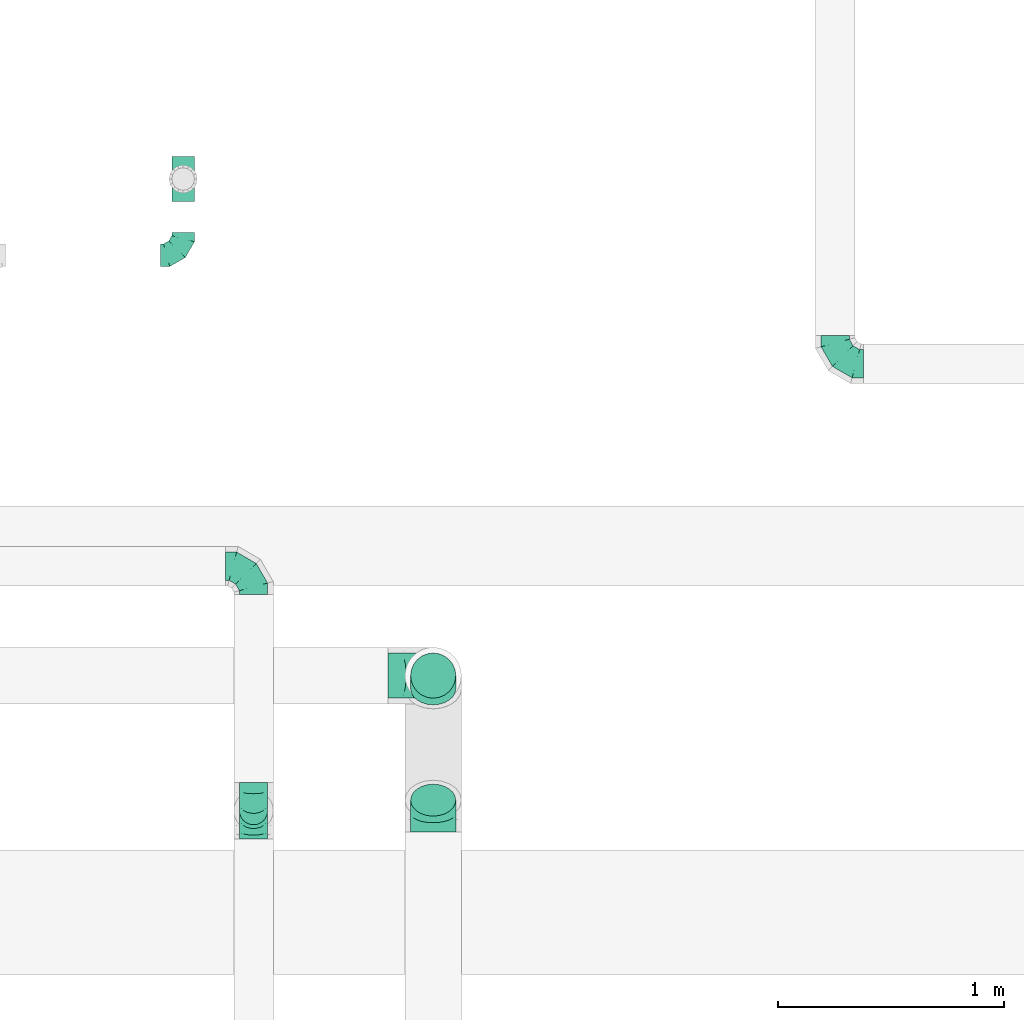
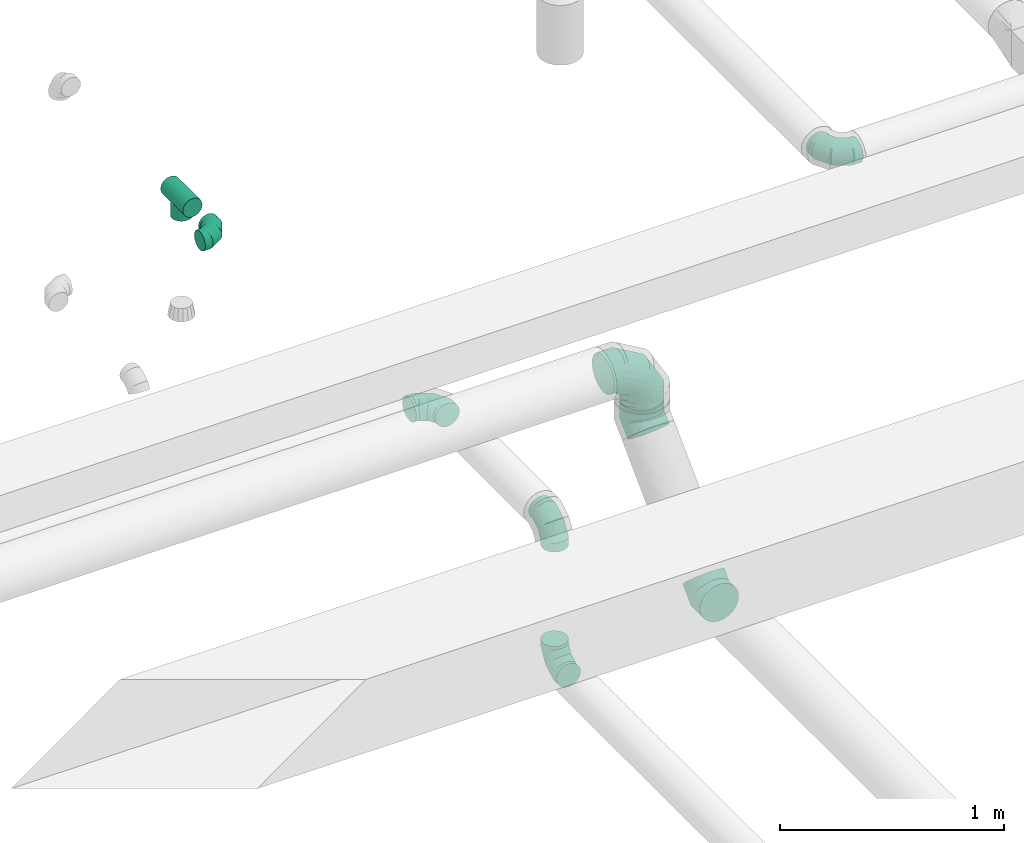
# One storey, part 71 of 97: 9 flow fittings.
"""IFC2X3 building model written with IfcOpenShell, lengths in millimetres."""

from ifc_helpers import new_model, entity, si_unit, converted_unit, derived_unit, direction, frame, origin, place, context, subcontext, project, spatial, faceted_brep, source, transform, mapped, material, type_object, type_shapes, element, save


model = new_model("IFC2X3")

# Units and contexts
model_context = context("Model", 3, precision=0.01, world=origin(), true_north=direction((6.12303176911189e-17, 1.0)))
body_context = subcontext(model_context, "Body", "Model", "MODEL_VIEW")
ifc_project = project(units=[si_unit("LENGTHUNIT", "METRE", prefix="MILLI"), si_unit("AREAUNIT", "SQUARE_METRE"), si_unit("VOLUMEUNIT", "CUBIC_METRE"), converted_unit("PLANEANGLEUNIT", "DEGREE", entity("IfcRatioMeasure", 0.0174532925199433), si_unit("PLANEANGLEUNIT", "RADIAN"), dimensions=[0, 0, 0, 0, 0, 0, 0]), si_unit("MASSUNIT", "GRAM", prefix="KILO"), derived_unit("MASSDENSITYUNIT", [(si_unit("MASSUNIT", "GRAM", prefix="KILO"), 1), (si_unit("LENGTHUNIT", "METRE"), -3)]), derived_unit("MOMENTOFINERTIAUNIT", [(si_unit("LENGTHUNIT", "METRE"), 4)]), si_unit("TIMEUNIT", "SECOND"), si_unit("FREQUENCYUNIT", "HERTZ"), si_unit("THERMODYNAMICTEMPERATUREUNIT", "DEGREE_CELSIUS"), derived_unit("THERMALTRANSMITTANCEUNIT", [(si_unit("MASSUNIT", "GRAM", prefix="KILO"), 1), (si_unit("THERMODYNAMICTEMPERATUREUNIT", "KELVIN"), -1), (si_unit("TIMEUNIT", "SECOND"), -3)]), derived_unit("VOLUMETRICFLOWRATEUNIT", [(si_unit("LENGTHUNIT", "METRE"), 3), (si_unit("TIMEUNIT", "SECOND"), -1)]), derived_unit("MASSFLOWRATEUNIT", [(si_unit("MASSUNIT", "GRAM", prefix="KILO"), 1), (si_unit("TIMEUNIT", "SECOND"), -1)]), derived_unit("ROTATIONALFREQUENCYUNIT", [(si_unit("TIMEUNIT", "SECOND"), -1)]), si_unit("ELECTRICCURRENTUNIT", "AMPERE"), si_unit("ELECTRICVOLTAGEUNIT", "VOLT"), si_unit("POWERUNIT", "WATT"), si_unit("FORCEUNIT", "NEWTON", prefix="KILO"), si_unit("ILLUMINANCEUNIT", "LUX"), si_unit("LUMINOUSFLUXUNIT", "LUMEN"), si_unit("LUMINOUSINTENSITYUNIT", "CANDELA"), derived_unit("USERDEFINED", [(si_unit("MASSUNIT", "GRAM", prefix="KILO"), -1), (si_unit("LENGTHUNIT", "METRE"), -2), (si_unit("TIMEUNIT", "SECOND"), 3), (si_unit("LUMINOUSFLUXUNIT", "LUMEN"), 1)]), derived_unit("LINEARVELOCITYUNIT", [(si_unit("LENGTHUNIT", "METRE"), 1), (si_unit("TIMEUNIT", "SECOND"), -1)]), si_unit("PRESSUREUNIT", "PASCAL"), derived_unit("USERDEFINED", [(si_unit("LENGTHUNIT", "METRE"), -2), (si_unit("MASSUNIT", "GRAM", prefix="KILO"), 1), (si_unit("TIMEUNIT", "SECOND"), -2)]), derived_unit("LINEARFORCEUNIT", [(si_unit("MASSUNIT", "GRAM", prefix="KILO"), 1), (si_unit("LENGTHUNIT", "METRE"), 1), (si_unit("TIMEUNIT", "SECOND"), -2), (si_unit("LENGTHUNIT", "METRE"), -1)]), derived_unit("PLANARFORCEUNIT", [(si_unit("MASSUNIT", "GRAM", prefix="KILO"), 1), (si_unit("LENGTHUNIT", "METRE"), 1), (si_unit("TIMEUNIT", "SECOND"), -2), (si_unit("LENGTHUNIT", "METRE"), -2)])], contexts=[model_context])

# Site, building, storey
site_placement = place(None, origin())
site = spatial("IfcSite", under=ifc_project, at=site_placement, CompositionType="ELEMENT")
building_placement = place(site_placement, origin())
building = spatial("IfcBuilding", under=site, at=building_placement, CompositionType="ELEMENT")
storey_placement = place(building_placement, frame((0.0, 0.0, -4900.0)))
storey = spatial("IfcBuildingStorey", under=building, at=storey_placement, CompositionType="ELEMENT", Elevation=-4900.0)

# Flow fittings
ifc_material = material()
duct_fitting_type_1 = type_object("IfcDuctFittingType", PredefinedType="NOTDEFINED", material=ifc_material)
shared_shape_1 = source(origin(), body_context, "Body", "Brep", [
    faceted_brep([(-100.0, 0.0, -50.0), (-100.0, -12.94, -48.3), (-100.0, -25.0, -43.3), (-100.0, -35.36, -35.36), (-100.0, -43.3, -25.0), (-100.0, -48.3, -12.94), (-100.0, -50.0, 0.0), (-100.0, -48.3, 12.94), (-100.0, -43.3, 25.0), (-100.0, -35.36, 35.36), (-100.0, -25.0, 43.3), (-100.0, -12.94, 48.3), (-100.0, 0.0, 50.0), (-100.0, 12.94, 48.3), (-100.0, 25.0, 43.3), (-100.0, 35.36, 35.36), (-100.0, 43.3, 25.0), (-100.0, 48.3, 12.94), (-100.0, 50.0, 0.0), (-100.0, 48.3, -12.94), (-100.0, 43.3, -25.0), (-100.0, 35.36, -35.36), (-100.0, 25.0, -43.3), (-100.0, 12.94, -48.3), (-76.67, 12.94, 48.3), (-79.9, 25.0, 43.3), (-73.21, 0.0, 50.0), (-82.68, 35.36, 35.36), (-86.15, 48.3, 12.94), (-86.6, 50.0, 0.0), (-84.81, 43.3, 25.0), (-84.81, 43.3, -25.0), (-82.68, 35.36, -35.36), (-86.15, 48.3, -12.94), (-76.67, 12.94, -48.3), (-73.21, 0.0, -50.0), (-79.9, 25.0, -43.3), (-69.74, -12.94, -48.3), (-66.51, -25.0, -43.3), (-63.73, -35.36, -35.36), (-61.6, -43.3, -25.0), (-60.26, -48.3, -12.94), (-59.81, -50.0, 0.0), (-60.26, -48.3, 12.94), (-61.6, -43.3, 25.0), (-63.73, -35.36, 35.36), (-66.51, -25.0, 43.3), (-69.74, -12.94, 48.3), (-36.27, 36.27, 48.3), (-45.1, 45.1, 43.3), (-26.79, 26.79, 50.0), (-52.68, 52.68, 35.36), (-58.49, 58.49, 25.0), (-62.15, 62.15, 12.94), (-63.4, 63.4, 0.0), (-62.15, 62.15, -12.94), (-58.49, 58.49, -25.0), (-52.68, 52.68, -35.36), (-36.27, 36.27, -48.3), (-26.79, 26.79, -50.0), (-45.1, 45.1, -43.3), (-17.32, 17.32, -48.3), (-8.49, 8.49, -43.3), (-0.91, 0.91, -35.36), (4.9, -4.9, -25.0), (8.56, -8.56, -12.94), (9.81, -9.81, 0.0), (8.56, -8.56, 12.94), (4.9, -4.9, 25.0), (-0.91, 0.91, 35.36), (-8.49, 8.49, 43.3), (-17.32, 17.32, 48.3), (-12.94, 76.67, 48.3), (-25.0, 79.9, 43.3), (0.0, 73.21, 50.0), (-35.36, 82.68, 35.36), (-43.3, 84.81, 25.0), (-48.3, 86.15, 12.94), (-50.0, 86.6, 0.0), (-48.3, 86.15, -12.94), (-43.3, 84.81, -25.0), (-35.36, 82.68, -35.36), (-12.94, 76.67, -48.3), (0.0, 73.21, -50.0), (-25.0, 79.9, -43.3), (12.94, 69.74, -48.3), (25.0, 66.51, -43.3), (35.36, 63.73, -35.36), (43.3, 61.6, -25.0), (48.3, 60.26, -12.94), (50.0, 59.81, 0.0), (48.3, 60.26, 12.94), (43.3, 61.6, 25.0), (35.36, 63.73, 35.36), (25.0, 66.51, 43.3), (12.94, 69.74, 48.3), (-12.94, 100.0, -48.3), (-25.0, 100.0, -43.3), (-35.36, 100.0, -35.36), (-43.3, 100.0, -25.0), (-48.3, 100.0, -12.94), (-50.0, 100.0, 0.0), (-48.3, 100.0, 12.94), (-43.3, 100.0, 25.0), (-35.36, 100.0, 35.36), (-25.0, 100.0, 43.3), (-12.94, 100.0, 48.3), (0.0, 100.0, 50.0), (12.94, 100.0, 48.3), (25.0, 100.0, 43.3), (35.36, 100.0, 35.36), (43.3, 100.0, 25.0), (48.3, 100.0, 12.94), (50.0, 100.0, 0.0), (48.3, 100.0, -12.94), (43.3, 100.0, -25.0), (35.36, 100.0, -35.36), (25.0, 100.0, -43.3), (12.94, 100.0, -48.3), (0.0, 100.0, -50.0)], [[[0, 1, 2, 3, 4, 5, 6, 7, 8, 9, 10, 11, 12, 13, 14, 15, 16, 17, 18, 19, 20, 21, 22, 23]], [[24, 25, 14, 13]], [[26, 24, 13, 12]], [[14, 25, 27, 15]], [[28, 29, 18, 17]], [[30, 28, 17, 16]], [[15, 27, 30, 16]], [[20, 31, 32, 21]], [[33, 31, 20, 19]], [[18, 29, 33, 19]], [[34, 35, 0, 23]], [[36, 34, 23, 22]], [[32, 36, 22, 21]], [[2, 1, 37, 38]], [[3, 2, 38, 39]], [[0, 35, 37, 1]], [[5, 4, 40, 41]], [[6, 5, 41, 42]], [[3, 39, 40, 4]], [[6, 42, 43, 7]], [[7, 43, 44, 8]], [[8, 44, 45, 9]], [[10, 46, 47, 11]], [[11, 47, 26, 12]], [[10, 9, 45, 46]], [[48, 49, 25, 24]], [[50, 48, 24, 26]], [[27, 25, 49, 51]], [[52, 53, 28, 30]], [[51, 52, 30, 27]], [[29, 28, 53, 54]], [[55, 56, 31, 33]], [[54, 55, 33, 29]], [[57, 32, 31, 56]], [[58, 59, 35, 34]], [[60, 58, 34, 36]], [[57, 60, 36, 32]], [[37, 35, 59, 61]], [[38, 37, 61, 62]], [[39, 38, 62, 63]], [[41, 40, 64, 65]], [[42, 41, 65, 66]], [[63, 64, 40, 39]], [[43, 42, 66, 67]], [[44, 43, 67, 68]], [[68, 69, 45, 44]], [[46, 45, 69, 70]], [[47, 46, 70, 71]], [[26, 47, 71, 50]], [[72, 73, 49, 48]], [[74, 72, 48, 50]], [[51, 49, 73, 75]], [[76, 77, 53, 52]], [[75, 76, 52, 51]], [[54, 53, 77, 78]], [[79, 80, 56, 55]], [[78, 79, 55, 54]], [[81, 57, 56, 80]], [[82, 83, 59, 58]], [[84, 82, 58, 60]], [[81, 84, 60, 57]], [[61, 59, 83, 85]], [[62, 61, 85, 86]], [[63, 62, 86, 87]], [[65, 64, 88, 89]], [[66, 65, 89, 90]], [[87, 88, 64, 63]], [[67, 66, 90, 91]], [[68, 67, 91, 92]], [[92, 93, 69, 68]], [[70, 69, 93, 94]], [[71, 70, 94, 95]], [[50, 71, 95, 74]], [[96, 97, 98, 99, 100, 101, 102, 103, 104, 105, 106, 107, 108, 109, 110, 111, 112, 113, 114, 115, 116, 117, 118, 119]], [[72, 74, 107, 106]], [[73, 72, 106, 105]], [[75, 73, 105, 104]], [[77, 76, 103, 102]], [[78, 77, 102, 101]], [[75, 104, 103, 76]], [[78, 101, 100, 79]], [[79, 100, 99, 80]], [[80, 99, 98, 81]], [[96, 119, 83, 82]], [[97, 96, 82, 84]], [[84, 81, 98, 97]], [[83, 119, 118, 85]], [[85, 118, 117, 86]], [[86, 117, 116, 87]], [[88, 115, 114, 89]], [[89, 114, 113, 90]], [[87, 116, 115, 88]], [[91, 90, 113, 112]], [[92, 91, 112, 111]], [[93, 92, 111, 110]], [[95, 94, 109, 108]], [[74, 95, 108, 107]], [[110, 109, 94, 93]]]),
])
type_shapes(duct_fitting_type_1, [shared_shape_1])
flow_fitting_1_placement = place(storey_placement, frame((63026.53, 11460.54, 4300.0)))
element("IfcFlowFitting", 1, at=flow_fitting_1_placement, inside=storey, type_object=duct_fitting_type_1, material=ifc_material, context=body_context, shape_type="MappedRepresentation", body=[
    mapped(shared_shape_1, transform((0.0, 0.0, 0.0), scale=1.0)),
])
duct_fitting_type_2 = type_object("IfcDuctFittingType", PredefinedType="NOTDEFINED", material=ifc_material)
shared_shape_2 = source(origin(), body_context, "Body", "Brep", [
    faceted_brep([(-200.0, 0.0, -100.0), (-200.0, -25.88, -96.59), (-200.0, -50.0, -86.6), (-200.0, -70.71, -70.71), (-200.0, -86.6, -50.0), (-200.0, -96.59, -25.88), (-200.0, -100.0, 0.0), (-200.0, -96.59, 25.88), (-200.0, -86.6, 50.0), (-200.0, -70.71, 70.71), (-200.0, -50.0, 86.6), (-200.0, -25.88, 96.59), (-200.0, 0.0, 100.0), (-200.0, 25.88, 96.59), (-200.0, 50.0, 86.6), (-200.0, 70.71, 70.71), (-200.0, 86.6, 50.0), (-200.0, 96.59, 25.88), (-200.0, 100.0, 0.0), (-200.0, 96.59, -25.88), (-200.0, 86.6, -50.0), (-200.0, 70.71, -70.71), (-200.0, 50.0, -86.6), (-200.0, 25.88, -96.59), (-153.35, 25.88, 96.59), (-159.81, 50.0, 86.6), (-146.41, 0.0, 100.0), (-165.36, 70.71, 70.71), (-172.29, 96.59, 25.88), (-173.21, 100.0, 0.0), (-169.62, 86.6, 50.0), (-169.62, 86.6, -50.0), (-165.36, 70.71, -70.71), (-172.29, 96.59, -25.88), (-153.35, 25.88, -96.59), (-146.41, 0.0, -100.0), (-159.81, 50.0, -86.6), (-139.48, -25.88, -96.59), (-133.01, -50.0, -86.6), (-127.46, -70.71, -70.71), (-123.21, -86.6, -50.0), (-120.53, -96.59, -25.88), (-119.62, -100.0, 0.0), (-120.53, -96.59, 25.88), (-123.21, -86.6, 50.0), (-127.46, -70.71, 70.71), (-133.01, -50.0, 86.6), (-139.48, -25.88, 96.59), (-72.54, 72.54, 96.59), (-90.19, 90.19, 86.6), (-53.59, 53.59, 100.0), (-105.35, 105.35, 70.71), (-116.99, 116.99, 50.0), (-124.3, 124.3, 25.88), (-126.79, 126.79, 0.0), (-124.3, 124.3, -25.88), (-116.99, 116.99, -50.0), (-105.35, 105.35, -70.71), (-72.54, 72.54, -96.59), (-53.59, 53.59, -100.0), (-90.19, 90.19, -86.6), (-34.64, 34.64, -96.59), (-16.99, 16.99, -86.6), (-1.83, 1.83, -70.71), (9.81, -9.81, -50.0), (17.12, -17.12, -25.88), (19.62, -19.62, 0.0), (17.12, -17.12, 25.88), (9.81, -9.81, 50.0), (-1.83, 1.83, 70.71), (-16.99, 16.99, 86.6), (-34.64, 34.64, 96.59), (-25.88, 153.35, 96.59), (-50.0, 159.81, 86.6), (0.0, 146.41, 100.0), (-70.71, 165.36, 70.71), (-86.6, 169.62, 50.0), (-96.59, 172.29, 25.88), (-100.0, 173.21, 0.0), (-96.59, 172.29, -25.88), (-86.6, 169.62, -50.0), (-70.71, 165.36, -70.71), (-25.88, 153.35, -96.59), (0.0, 146.41, -100.0), (-50.0, 159.81, -86.6), (25.88, 139.48, -96.59), (50.0, 133.01, -86.6), (70.71, 127.46, -70.71), (86.6, 123.21, -50.0), (96.59, 120.53, -25.88), (100.0, 119.62, 0.0), (96.59, 120.53, 25.88), (86.6, 123.21, 50.0), (70.71, 127.46, 70.71), (50.0, 133.01, 86.6), (25.88, 139.48, 96.59), (-25.88, 200.0, -96.59), (-50.0, 200.0, -86.6), (-70.71, 200.0, -70.71), (-86.6, 200.0, -50.0), (-96.59, 200.0, -25.88), (-100.0, 200.0, 0.0), (-96.59, 200.0, 25.88), (-86.6, 200.0, 50.0), (-70.71, 200.0, 70.71), (-50.0, 200.0, 86.6), (-25.88, 200.0, 96.59), (0.0, 200.0, 100.0), (25.88, 200.0, 96.59), (50.0, 200.0, 86.6), (70.71, 200.0, 70.71), (86.6, 200.0, 50.0), (96.59, 200.0, 25.88), (100.0, 200.0, 0.0), (96.59, 200.0, -25.88), (86.6, 200.0, -50.0), (70.71, 200.0, -70.71), (50.0, 200.0, -86.6), (25.88, 200.0, -96.59), (0.0, 200.0, -100.0)], [[[0, 1, 2, 3, 4, 5, 6, 7, 8, 9, 10, 11, 12, 13, 14, 15, 16, 17, 18, 19, 20, 21, 22, 23]], [[24, 25, 14, 13]], [[26, 24, 13, 12]], [[14, 25, 27, 15]], [[28, 29, 18, 17]], [[30, 28, 17, 16]], [[15, 27, 30, 16]], [[20, 31, 32, 21]], [[33, 31, 20, 19]], [[18, 29, 33, 19]], [[34, 35, 0, 23]], [[36, 34, 23, 22]], [[32, 36, 22, 21]], [[1, 0, 35, 37]], [[2, 1, 37, 38]], [[38, 39, 3, 2]], [[5, 4, 40, 41]], [[6, 5, 41, 42]], [[39, 40, 4, 3]], [[6, 42, 43, 7]], [[7, 43, 44, 8]], [[8, 44, 45, 9]], [[9, 45, 46, 10]], [[10, 46, 47, 11]], [[26, 12, 11, 47]], [[48, 49, 25, 24]], [[50, 48, 24, 26]], [[27, 25, 49, 51]], [[52, 53, 28, 30]], [[51, 52, 30, 27]], [[29, 28, 53, 54]], [[55, 56, 31, 33]], [[54, 55, 33, 29]], [[32, 31, 56, 57]], [[58, 59, 35, 34]], [[60, 58, 34, 36]], [[57, 60, 36, 32]], [[37, 35, 59, 61]], [[38, 37, 61, 62]], [[39, 38, 62, 63]], [[41, 40, 64, 65]], [[42, 41, 65, 66]], [[63, 64, 40, 39]], [[43, 42, 66, 67]], [[44, 43, 67, 68]], [[68, 69, 45, 44]], [[46, 45, 69, 70]], [[47, 46, 70, 71]], [[26, 47, 71, 50]], [[72, 73, 49, 48]], [[74, 72, 48, 50]], [[51, 49, 73, 75]], [[76, 77, 53, 52]], [[75, 76, 52, 51]], [[54, 53, 77, 78]], [[79, 80, 56, 55]], [[78, 79, 55, 54]], [[57, 56, 80, 81]], [[82, 83, 59, 58]], [[84, 82, 58, 60]], [[81, 84, 60, 57]], [[61, 59, 83, 85]], [[62, 61, 85, 86]], [[63, 62, 86, 87]], [[65, 64, 88, 89]], [[66, 65, 89, 90]], [[87, 88, 64, 63]], [[67, 66, 90, 91]], [[68, 67, 91, 92]], [[92, 93, 69, 68]], [[70, 69, 93, 94]], [[71, 70, 94, 95]], [[50, 71, 95, 74]], [[96, 97, 98, 99, 100, 101, 102, 103, 104, 105, 106, 107, 108, 109, 110, 111, 112, 113, 114, 115, 116, 117, 118, 119]], [[72, 74, 107, 106]], [[73, 72, 106, 105]], [[75, 73, 105, 104]], [[102, 101, 78, 77]], [[103, 102, 77, 76]], [[75, 104, 103, 76]], [[78, 101, 100, 79]], [[79, 100, 99, 80]], [[80, 99, 98, 81]], [[84, 97, 96, 82]], [[82, 96, 119, 83]], [[84, 81, 98, 97]], [[118, 117, 86, 85]], [[119, 118, 85, 83]], [[116, 87, 86, 117]], [[88, 115, 114, 89]], [[89, 114, 113, 90]], [[115, 88, 87, 116]], [[91, 90, 113, 112]], [[92, 91, 112, 111]], [[111, 110, 93, 92]], [[95, 94, 109, 108]], [[74, 95, 108, 107]], [[110, 109, 94, 93]]]),
])
type_shapes(duct_fitting_type_2, [shared_shape_2])
flow_fitting_2_placement = place(storey_placement, frame((64133.78, 9598.98, 4350.0), z_axis=(0.0, -1.0, 0.0), x_axis=(0.0, 0.0, 1.0)))
element("IfcFlowFitting", 2, at=flow_fitting_2_placement, inside=storey, type_object=duct_fitting_type_2, material=ifc_material, context=body_context, shape_type="MappedRepresentation", body=[
    mapped(shared_shape_2, transform((0.0, 0.0, 0.0), scale=1.0)),
])
duct_fitting_type_3 = type_object("IfcDuctFittingType", PredefinedType="NOTDEFINED", material=ifc_material)
shared_shape_3 = source(origin(), body_context, "Body", "Brep", [
    faceted_brep([(-125.0, 0.0, -62.5), (-125.0, -16.18, -60.37), (-125.0, -31.25, -54.13), (-125.0, -44.19, -44.19), (-125.0, -54.13, -31.25), (-125.0, -60.37, -16.18), (-125.0, -62.5, 0.0), (-125.0, -60.37, 16.18), (-125.0, -54.13, 31.25), (-125.0, -44.19, 44.19), (-125.0, -31.25, 54.13), (-125.0, -16.18, 60.37), (-125.0, 0.0, 62.5), (-125.0, 16.18, 60.37), (-125.0, 31.25, 54.13), (-125.0, 44.19, 44.19), (-125.0, 54.13, 31.25), (-125.0, 60.37, 16.18), (-125.0, 62.5, 0.0), (-125.0, 60.37, -16.18), (-125.0, 54.13, -31.25), (-125.0, 44.19, -44.19), (-125.0, 31.25, -54.13), (-125.0, 16.18, -60.37), (-95.84, 16.18, 60.37), (-99.88, 31.25, 54.13), (-91.51, 0.0, 62.5), (-103.35, 44.19, 44.19), (-107.68, 60.37, 16.18), (-108.25, 62.5, 0.0), (-106.01, 54.13, 31.25), (-106.01, 54.13, -31.25), (-103.35, 44.19, -44.19), (-107.68, 60.37, -16.18), (-95.84, 16.18, -60.37), (-91.51, 0.0, -62.5), (-99.88, 31.25, -54.13), (-87.17, -16.18, -60.37), (-83.13, -31.25, -54.13), (-79.66, -44.19, -44.19), (-77.0, -54.13, -31.25), (-75.33, -60.37, -16.18), (-74.76, -62.5, 0.0), (-75.33, -60.37, 16.18), (-77.0, -54.13, 31.25), (-79.66, -44.19, 44.19), (-83.13, -31.25, 54.13), (-87.17, -16.18, 60.37), (-45.34, 45.34, 60.37), (-56.37, 56.37, 54.13), (-33.49, 33.49, 62.5), (-65.85, 65.85, 44.19), (-73.12, 73.12, 31.25), (-77.69, 77.69, 16.18), (-79.25, 79.25, 0.0), (-77.69, 77.69, -16.18), (-73.12, 73.12, -31.25), (-65.85, 65.85, -44.19), (-45.34, 45.34, -60.37), (-33.49, 33.49, -62.5), (-56.37, 56.37, -54.13), (-21.65, 21.65, -60.37), (-10.62, 10.62, -54.13), (-1.14, 1.14, -44.19), (6.13, -6.13, -31.25), (10.7, -10.7, -16.18), (12.26, -12.26, 0.0), (10.7, -10.7, 16.18), (6.13, -6.13, 31.25), (-1.14, 1.14, 44.19), (-10.62, 10.62, 54.13), (-21.65, 21.65, 60.37), (-16.18, 95.84, 60.37), (-31.25, 99.88, 54.13), (0.0, 91.51, 62.5), (-44.19, 103.35, 44.19), (-54.13, 106.01, 31.25), (-60.37, 107.68, 16.18), (-62.5, 108.25, 0.0), (-60.37, 107.68, -16.18), (-54.13, 106.01, -31.25), (-44.19, 103.35, -44.19), (-16.18, 95.84, -60.37), (0.0, 91.51, -62.5), (-31.25, 99.88, -54.13), (16.18, 87.17, -60.37), (31.25, 83.13, -54.13), (44.19, 79.66, -44.19), (54.13, 77.0, -31.25), (60.37, 75.33, -16.18), (62.5, 74.76, 0.0), (60.37, 75.33, 16.18), (54.13, 77.0, 31.25), (44.19, 79.66, 44.19), (31.25, 83.13, 54.13), (16.18, 87.17, 60.37), (-16.18, 125.0, -60.37), (-31.25, 125.0, -54.13), (-44.19, 125.0, -44.19), (-54.13, 125.0, -31.25), (-60.37, 125.0, -16.18), (-62.5, 125.0, 0.0), (-60.37, 125.0, 16.18), (-54.13, 125.0, 31.25), (-44.19, 125.0, 44.19), (-31.25, 125.0, 54.13), (-16.18, 125.0, 60.37), (0.0, 125.0, 62.5), (16.18, 125.0, 60.37), (31.25, 125.0, 54.13), (44.19, 125.0, 44.19), (54.13, 125.0, 31.25), (60.37, 125.0, 16.18), (62.5, 125.0, 0.0), (60.37, 125.0, -16.18), (54.13, 125.0, -31.25), (44.19, 125.0, -44.19), (31.25, 125.0, -54.13), (16.18, 125.0, -60.37), (0.0, 125.0, -62.5)], [[[0, 1, 2, 3, 4, 5, 6, 7, 8, 9, 10, 11, 12, 13, 14, 15, 16, 17, 18, 19, 20, 21, 22, 23]], [[24, 25, 14, 13]], [[26, 24, 13, 12]], [[14, 25, 27, 15]], [[28, 29, 18, 17]], [[30, 28, 17, 16]], [[15, 27, 30, 16]], [[20, 31, 32, 21]], [[33, 31, 20, 19]], [[18, 29, 33, 19]], [[34, 35, 0, 23]], [[36, 34, 23, 22]], [[21, 32, 36, 22]], [[1, 0, 35, 37]], [[2, 1, 37, 38]], [[38, 39, 3, 2]], [[5, 4, 40, 41]], [[6, 5, 41, 42]], [[39, 40, 4, 3]], [[6, 42, 43, 7]], [[7, 43, 44, 8]], [[45, 9, 8, 44]], [[9, 45, 46, 10]], [[10, 46, 47, 11]], [[26, 12, 11, 47]], [[48, 49, 25, 24]], [[50, 48, 24, 26]], [[27, 25, 49, 51]], [[52, 53, 28, 30]], [[51, 52, 30, 27]], [[29, 28, 53, 54]], [[55, 56, 31, 33]], [[54, 55, 33, 29]], [[57, 32, 31, 56]], [[58, 59, 35, 34]], [[60, 58, 34, 36]], [[57, 60, 36, 32]], [[37, 35, 59, 61]], [[38, 37, 61, 62]], [[39, 38, 62, 63]], [[41, 40, 64, 65]], [[42, 41, 65, 66]], [[63, 64, 40, 39]], [[43, 42, 66, 67]], [[44, 43, 67, 68]], [[68, 69, 45, 44]], [[46, 45, 69, 70]], [[47, 46, 70, 71]], [[26, 47, 71, 50]], [[72, 73, 49, 48]], [[74, 72, 48, 50]], [[51, 49, 73, 75]], [[76, 77, 53, 52]], [[75, 76, 52, 51]], [[54, 53, 77, 78]], [[79, 80, 56, 55]], [[78, 79, 55, 54]], [[81, 57, 56, 80]], [[82, 83, 59, 58]], [[84, 82, 58, 60]], [[81, 84, 60, 57]], [[61, 59, 83, 85]], [[62, 61, 85, 86]], [[63, 62, 86, 87]], [[65, 64, 88, 89]], [[66, 65, 89, 90]], [[87, 88, 64, 63]], [[67, 66, 90, 91]], [[68, 67, 91, 92]], [[92, 93, 69, 68]], [[70, 69, 93, 94]], [[71, 70, 94, 95]], [[50, 71, 95, 74]], [[96, 97, 98, 99, 100, 101, 102, 103, 104, 105, 106, 107, 108, 109, 110, 111, 112, 113, 114, 115, 116, 117, 118, 119]], [[72, 74, 107, 106]], [[73, 72, 106, 105]], [[75, 73, 105, 104]], [[77, 76, 103, 102]], [[78, 77, 102, 101]], [[75, 104, 103, 76]], [[78, 101, 100, 79]], [[79, 100, 99, 80]], [[80, 99, 98, 81]], [[96, 119, 83, 82]], [[97, 96, 82, 84]], [[84, 81, 98, 97]], [[83, 119, 118, 85]], [[85, 118, 117, 86]], [[116, 87, 86, 117]], [[88, 115, 114, 89]], [[89, 114, 113, 90]], [[115, 88, 87, 116]], [[91, 90, 113, 112]], [[92, 91, 112, 111]], [[111, 110, 93, 92]], [[95, 94, 109, 108]], [[74, 95, 108, 107]], [[110, 109, 94, 93]]]),
])
type_shapes(duct_fitting_type_3, [shared_shape_3])
for number, where, z_axis, x_axis in (
    (3, (63338.11, 9001.07, 4115.0), (1.0, 0.0, 0.0), (0.0, -1.0, 0.0)),
    (4, (65913.93, 10980.22, 4000.0), (0.0, 0.0, 1.0), (0.0, -1.0, 0.0)),
    (5, (63338.11, 10083.58, 4115.0), (0.0, 0.0, 1.0), (0.0, 1.0, 0.0)),
    (6, (63338.11, 9001.07, 3350.0), (-1.0, 0.0, 0.0), (0.0, 0.0, -1.0)),
):
    element("IfcFlowFitting", number, at=place(storey_placement, frame(where, z_axis=z_axis, x_axis=x_axis)), inside=storey, type_object=duct_fitting_type_3, material=ifc_material, context=body_context, shape_type="MappedRepresentation", body=[
        mapped(shared_shape_3, transform((0.0, 0.0, 0.0), scale=1.0)),
    ])
duct_fitting_type_4 = type_object("IfcDuctFittingType", PredefinedType="NOTDEFINED", material=ifc_material)
shared_shape_4 = source(origin(), body_context, "Body", "Brep", [
    faceted_brep([(6.73, -6.73, -49.54), (100.0, 0.0, -50.0), (100.0, -12.94, -48.3), (100.0, -25.0, -43.3), (19.94, -19.94, -45.85), (32.27, -32.27, -38.19), (100.0, -35.36, -35.36), (26.27, -26.27, -42.54), (0.0, 0.0, -50.0), (-6.73, -6.73, -49.54), (-100.0, 0.0, -50.0), (13.4, -13.4, -48.17), (37.8, -37.8, -32.73), (100.0, -43.3, -25.0), (46.54, -46.54, -18.28), (100.0, -48.3, -12.94), (49.1, -49.1, -9.45), (100.0, -50.0, 0.0), (42.66, -42.66, -26.08), (50.0, -50.0, 0.0), (-100.0, -50.0, 0.0), (-49.1, -49.1, -9.45), (-50.0, -50.0, 0.0), (49.1, -49.1, 9.45), (100.0, -48.3, 12.94), (46.54, -46.54, 18.28), (100.0, -43.3, 25.0), (37.8, -37.8, 32.73), (100.0, -35.36, 35.36), (-49.1, -49.1, 9.45), (42.66, -42.66, 26.08), (32.27, -32.27, 38.19), (26.27, -26.27, 42.54), (100.0, -25.0, 43.3), (19.94, -19.94, 45.85), (100.0, -12.94, 48.3), (6.73, -6.73, 49.54), (100.0, 0.0, 50.0), (13.4, -13.4, 48.17), (0.0, 0.0, 50.0), (-6.73, -6.73, 49.54), (-100.0, 0.0, 50.0), (12.94, -100.0, -48.3), (25.0, -100.0, -43.3), (35.36, -100.0, -35.36), (43.3, -100.0, -25.0), (48.3, -100.0, -12.94), (50.0, -100.0, 0.0), (48.3, -100.0, 12.94), (43.3, -100.0, 25.0), (35.36, -100.0, 35.36), (25.0, -100.0, 43.3), (12.94, -100.0, 48.3), (0.0, -100.0, 50.0), (-12.94, -100.0, 48.3), (-25.0, -100.0, 43.3), (-35.36, -100.0, 35.36), (-43.3, -100.0, 25.0), (-48.3, -100.0, 12.94), (-50.0, -100.0, 0.0), (-48.3, -100.0, -12.94), (-43.3, -100.0, -25.0), (-35.36, -100.0, -35.36), (-25.0, -100.0, -43.3), (-12.94, -100.0, -48.3), (0.0, -100.0, -50.0), (-19.94, -19.94, -45.85), (-32.27, -32.27, -38.19), (-26.27, -26.27, -42.54), (-13.4, -13.4, -48.17), (-37.8, -37.8, -32.73), (-46.54, -46.54, -18.28), (-42.66, -42.66, -26.08), (-46.54, -46.54, 18.28), (-37.8, -37.8, 32.73), (-42.66, -42.66, 26.08), (-32.27, -32.27, 38.19), (-26.27, -26.27, 42.54), (-19.94, -19.94, 45.85), (-13.4, -13.4, 48.17), (-100.0, -12.94, -48.3), (-100.0, -25.0, -43.3), (-100.0, -35.36, -35.36), (-100.0, -43.3, -25.0), (-100.0, -48.3, -12.94), (-100.0, -48.3, 12.94), (-100.0, -43.3, 25.0), (-100.0, -35.36, 35.36), (-100.0, -25.0, 43.3), (-100.0, -12.94, 48.3), (-100.0, 12.94, 48.3), (-100.0, 25.0, 43.3), (-100.0, 35.36, 35.36), (-100.0, 43.3, 25.0), (-100.0, 48.3, 12.94), (-100.0, 50.0, 0.0), (-100.0, 48.3, -12.94), (-100.0, 43.3, -25.0), (-100.0, 35.36, -35.36), (-100.0, 25.0, -43.3), (-100.0, 12.94, -48.3), (100.0, 12.94, -48.3), (100.0, 25.0, -43.3), (100.0, 35.36, -35.36), (100.0, 43.3, -25.0), (100.0, 48.3, -12.94), (100.0, 50.0, 0.0), (100.0, 48.3, 12.94), (100.0, 43.3, 25.0), (100.0, 35.36, 35.36), (100.0, 25.0, 43.3), (100.0, 12.94, 48.3)], [[[0, 1, 2]], [[2, 3, 4]], [[5, 3, 6]], [[5, 7, 3]], [[0, 8, 1]], [[8, 9, 10]], [[4, 11, 2]], [[7, 4, 3]], [[0, 2, 11]], [[12, 6, 13]], [[14, 13, 15]], [[16, 15, 17]], [[18, 12, 13]], [[16, 14, 15]], [[19, 16, 17]], [[20, 21, 22]], [[18, 13, 14]], [[6, 12, 5]], [[23, 17, 24]], [[25, 24, 26]], [[27, 26, 28]], [[23, 19, 17]], [[22, 29, 20]], [[30, 25, 26]], [[27, 30, 26]], [[23, 24, 25]], [[28, 31, 27]], [[32, 31, 33]], [[33, 31, 28]], [[34, 33, 35]], [[36, 35, 37]], [[34, 32, 33]], [[36, 38, 35]], [[39, 36, 37]], [[40, 39, 41]], [[34, 35, 38]], [[42, 43, 44, 45, 46, 47, 48, 49, 50, 51, 52, 53, 54, 55, 56, 57, 58, 59, 60, 61, 62, 63, 64, 65]], [[36, 53, 52]], [[52, 51, 34]], [[31, 51, 50]], [[31, 32, 51]], [[36, 39, 53]], [[34, 38, 52]], [[32, 34, 51]], [[36, 52, 38]], [[27, 50, 49]], [[25, 49, 48]], [[23, 48, 47]], [[30, 27, 49]], [[23, 25, 48]], [[19, 23, 47]], [[30, 49, 25]], [[50, 27, 31]], [[47, 46, 16]], [[45, 44, 12]], [[46, 45, 14]], [[16, 19, 47]], [[18, 14, 45]], [[12, 18, 45]], [[16, 46, 14]], [[44, 5, 12]], [[7, 5, 43]], [[43, 5, 44]], [[4, 43, 42]], [[0, 42, 65]], [[4, 7, 43]], [[0, 11, 42]], [[8, 0, 65]], [[4, 42, 11]], [[9, 65, 64]], [[64, 63, 66]], [[67, 63, 62]], [[67, 68, 63]], [[9, 8, 65]], [[66, 69, 64]], [[68, 66, 63]], [[9, 64, 69]], [[70, 62, 61]], [[71, 61, 60]], [[21, 60, 59]], [[72, 70, 61]], [[21, 71, 60]], [[22, 21, 59]], [[72, 61, 71]], [[62, 70, 67]], [[29, 59, 58]], [[73, 58, 57]], [[74, 57, 56]], [[29, 22, 59]], [[75, 73, 57]], [[74, 75, 57]], [[29, 58, 73]], [[56, 76, 74]], [[77, 76, 55]], [[55, 76, 56]], [[78, 55, 54]], [[40, 54, 53]], [[78, 77, 55]], [[40, 79, 54]], [[39, 40, 53]], [[78, 54, 79]], [[10, 80, 81, 82, 83, 84, 20, 85, 86, 87, 88, 89, 41, 90, 91, 92, 93, 94, 95, 96, 97, 98, 99, 100]], [[101, 102, 103, 104, 105, 106, 107, 108, 109, 110, 111, 37, 35, 33, 28, 26, 24, 17, 15, 13, 6, 3, 2, 1]], [[39, 37, 111, 90, 41]], [[91, 90, 111, 110]], [[110, 109, 92, 91]], [[93, 92, 109, 108]], [[94, 93, 108, 107]], [[95, 94, 107, 106]], [[105, 104, 97, 96]], [[106, 105, 96, 95]], [[104, 103, 98, 97]], [[99, 98, 103, 102]], [[100, 99, 102, 101]], [[8, 10, 100, 101, 1]], [[69, 66, 80]], [[9, 69, 80]], [[10, 9, 80]], [[81, 68, 67]], [[81, 80, 66]], [[81, 67, 82]], [[68, 81, 66]], [[70, 72, 83]], [[71, 21, 84]], [[72, 71, 83]], [[82, 70, 83]], [[21, 20, 84]], [[84, 83, 71]], [[70, 82, 67]], [[29, 73, 85]], [[75, 74, 86]], [[73, 75, 86]], [[85, 20, 29]], [[73, 86, 85]], [[74, 87, 86]], [[74, 76, 87]], [[78, 79, 89]], [[79, 40, 89]], [[76, 77, 88]], [[78, 88, 77]], [[78, 89, 88]], [[40, 41, 89]], [[76, 88, 87]]]),
])
type_shapes(duct_fitting_type_4, [shared_shape_4])
flow_fitting_3_placement = place(storey_placement, frame((63026.53, 11797.88, 4300.0), z_axis=(-1.0, 0.0, 0.0), x_axis=(0.0, -1.0, 0.0)))
element("IfcFlowFitting", 7, at=flow_fitting_3_placement, inside=storey, type_object=duct_fitting_type_4, material=ifc_material, context=body_context, shape_type="MappedRepresentation", body=[
    mapped(shared_shape_4, transform((0.0, 0.0, 0.0), scale=1.0)),
])
duct_fitting_type_5 = type_object("IfcDuctFittingType", PredefinedType="NOTDEFINED", material=ifc_material)
shared_shape_5 = source(origin(), body_context, "Body", "Brep", [
    faceted_brep([(-82.84, 0.0, -100.0), (-82.84, -25.88, -96.59), (-82.84, -50.0, -86.6), (-82.84, -70.71, -70.71), (-82.84, -86.6, -50.0), (-82.84, -96.59, -25.88), (-82.84, -100.0, 0.0), (-82.84, -96.59, 25.88), (-82.84, -86.6, 50.0), (-82.84, -70.71, 70.71), (-82.84, -50.0, 86.6), (-82.84, -25.88, 96.59), (-82.84, 0.0, 100.0), (-82.84, 25.88, 96.59), (-82.84, 50.0, 86.6), (-82.84, 70.71, 70.71), (-82.84, 86.6, 50.0), (-82.84, 96.59, 25.88), (-82.84, 100.0, 0.0), (-82.84, 96.59, -25.88), (-82.84, 86.6, -50.0), (-82.84, 70.71, -70.71), (-82.84, 50.0, -86.6), (-82.84, 25.88, -96.59), (-10.72, 25.88, 96.59), (-20.71, 50.0, 86.6), (0.0, 0.0, 100.0), (-29.29, 70.71, 70.71), (-35.87, 86.6, 50.0), (-40.01, 96.59, 25.88), (-41.42, 100.0, 0.0), (-40.01, 96.59, -25.88), (-35.87, 86.6, -50.0), (-29.29, 70.71, -70.71), (-10.72, 25.88, -96.59), (0.0, 0.0, -100.0), (-20.71, 50.0, -86.6), (10.72, -25.88, -96.59), (20.71, -50.0, -86.6), (29.29, -70.71, -70.71), (35.87, -86.6, -50.0), (40.01, -96.59, -25.88), (41.42, -100.0, 0.0), (40.01, -96.59, 25.88), (35.87, -86.6, 50.0), (29.29, -70.71, 70.71), (20.71, -50.0, 86.6), (10.72, -25.88, 96.59), (58.58, 58.58, 100.0), (40.28, 76.88, 96.59), (23.22, 93.93, 86.6), (8.58, 108.58, 70.71), (-2.66, 119.82, 50.0), (-9.72, 126.88, 25.88), (-12.13, 129.29, 0.0), (-9.72, 126.88, -25.88), (-2.66, 119.82, -50.0), (8.58, 108.58, -70.71), (23.22, 93.93, -86.6), (40.28, 76.88, -96.59), (58.58, 58.58, -100.0), (76.88, 40.28, -96.59), (93.93, 23.22, -86.6), (108.58, 8.58, -70.71), (119.82, -2.66, -50.0), (126.88, -9.72, -25.88), (129.29, -12.13, 0.0), (126.88, -9.72, 25.88), (119.82, -2.66, 50.0), (108.58, 8.58, 70.71), (93.93, 23.22, 86.6), (76.88, 40.28, 96.59)], [[[0, 1, 2, 3, 4, 5, 6, 7, 8, 9, 10, 11, 12, 13, 14, 15, 16, 17, 18, 19, 20, 21, 22, 23]], [[24, 25, 14, 13]], [[26, 24, 13, 12]], [[14, 25, 27, 15]], [[28, 29, 17, 16]], [[28, 16, 15, 27]], [[30, 18, 17, 29]], [[31, 32, 20, 19]], [[30, 31, 19, 18]], [[32, 33, 21, 20]], [[34, 35, 0, 23]], [[36, 34, 23, 22]], [[33, 36, 22, 21]], [[1, 0, 35, 37]], [[2, 1, 37, 38]], [[38, 39, 3, 2]], [[5, 4, 40, 41]], [[6, 5, 41, 42]], [[39, 40, 4, 3]], [[6, 42, 43, 7]], [[7, 43, 44, 8]], [[8, 44, 45, 9]], [[9, 45, 46, 10]], [[10, 46, 47, 11]], [[26, 12, 11, 47]], [[24, 26, 48, 49]], [[25, 24, 49, 50]], [[27, 25, 50, 51]], [[29, 28, 52, 53]], [[30, 29, 53, 54]], [[51, 52, 28, 27]], [[30, 54, 55, 31]], [[31, 55, 56, 32]], [[57, 33, 32, 56]], [[36, 58, 59, 34]], [[34, 59, 60, 35]], [[58, 36, 33, 57]], [[35, 60, 61, 37]], [[37, 61, 62, 38]], [[63, 39, 38, 62]], [[40, 64, 65, 41]], [[41, 65, 66, 42]], [[64, 40, 39, 63]], [[43, 42, 66, 67]], [[44, 43, 67, 68]], [[68, 69, 45, 44]], [[47, 46, 70, 71]], [[26, 47, 71, 48]], [[69, 70, 46, 45]], [[59, 58, 57, 56, 55, 54, 53, 52, 51, 50, 49, 48, 71, 70, 69, 68, 67, 66, 65, 64, 63, 62, 61, 60]]]),
])
type_shapes(duct_fitting_type_5, [shared_shape_5])
for number, where, z_axis, x_axis in (
    (8, (64133.78, 8988.98, 3450.0), (1.0, 0.0, 0.0), (0.0, 1.0, 0.0)),
    (9, (64133.78, 9598.98, 4060.0), (-1.0, 0.0, 0.0), (0.0, 0.0, -1.0)),
):
    element("IfcFlowFitting", number, at=place(storey_placement, frame(where, z_axis=z_axis, x_axis=x_axis)), inside=storey, type_object=duct_fitting_type_5, material=ifc_material, context=body_context, shape_type="MappedRepresentation", body=[
        mapped(shared_shape_5, transform((0.0, 0.0, 0.0), scale=1.0)),
    ])

save(model, "model.ifc")
